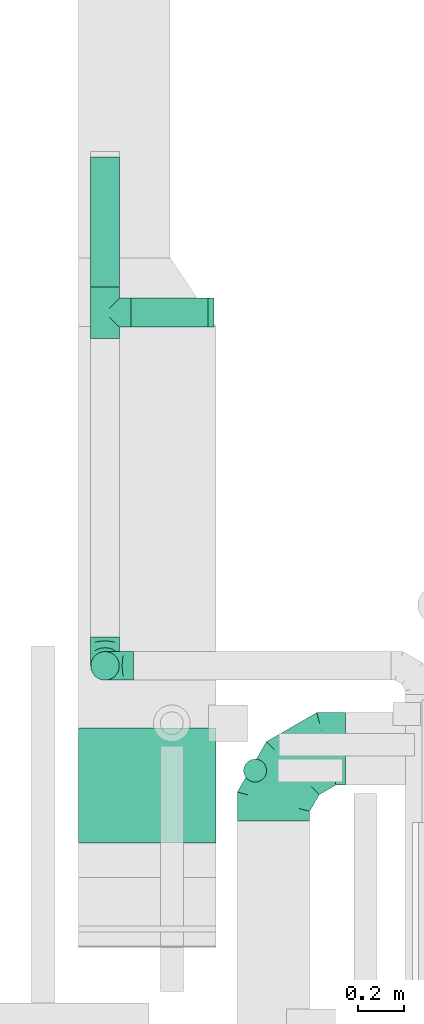
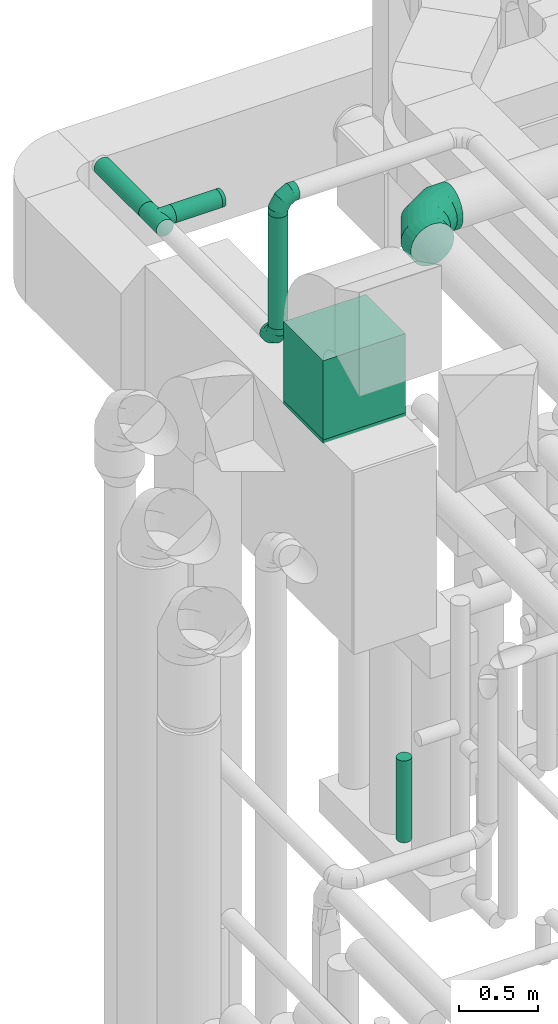
# One storey, part 273 of 337: 6 flow fittings, 5 flow segments.
"""IFC2X3 building model written with IfcOpenShell, lengths in millimetres."""

from ifc_helpers import new_model, entity, si_unit, converted_unit, derived_unit, direction, frame, origin, origin_2d_with_axis, place, context, subcontext, project, spatial, rectangle, circle, extrude, faceted_brep, source, transform, mapped, material, type_object, type_shapes, element, save


model = new_model("IFC2X3")

# Units and contexts
model_context = context("Model", 3, precision=0.01, world=origin(), true_north=direction((6.12303176911189e-17, 1.0)))
body_context = subcontext(model_context, "Body", "Model", "MODEL_VIEW")
ifc_project = project(units=[si_unit("LENGTHUNIT", "METRE", prefix="MILLI"), si_unit("AREAUNIT", "SQUARE_METRE"), si_unit("VOLUMEUNIT", "CUBIC_METRE"), converted_unit("PLANEANGLEUNIT", "DEGREE", entity("IfcRatioMeasure", 0.0174532925199433), si_unit("PLANEANGLEUNIT", "RADIAN"), dimensions=[0, 0, 0, 0, 0, 0, 0]), si_unit("MASSUNIT", "GRAM", prefix="KILO"), derived_unit("MASSDENSITYUNIT", [(si_unit("MASSUNIT", "GRAM", prefix="KILO"), 1), (si_unit("LENGTHUNIT", "METRE"), -3)]), derived_unit("MOMENTOFINERTIAUNIT", [(si_unit("LENGTHUNIT", "METRE"), 4)]), si_unit("TIMEUNIT", "SECOND"), si_unit("FREQUENCYUNIT", "HERTZ"), si_unit("THERMODYNAMICTEMPERATUREUNIT", "DEGREE_CELSIUS"), derived_unit("THERMALTRANSMITTANCEUNIT", [(si_unit("MASSUNIT", "GRAM", prefix="KILO"), 1), (si_unit("THERMODYNAMICTEMPERATUREUNIT", "KELVIN"), -1), (si_unit("TIMEUNIT", "SECOND"), -3)]), derived_unit("VOLUMETRICFLOWRATEUNIT", [(si_unit("LENGTHUNIT", "METRE"), 3), (si_unit("TIMEUNIT", "SECOND"), -1)]), derived_unit("MASSFLOWRATEUNIT", [(si_unit("MASSUNIT", "GRAM", prefix="KILO"), 1), (si_unit("TIMEUNIT", "SECOND"), -1)]), derived_unit("ROTATIONALFREQUENCYUNIT", [(si_unit("TIMEUNIT", "SECOND"), -1)]), si_unit("ELECTRICCURRENTUNIT", "AMPERE"), si_unit("ELECTRICVOLTAGEUNIT", "VOLT"), si_unit("POWERUNIT", "WATT"), si_unit("FORCEUNIT", "NEWTON", prefix="KILO"), si_unit("ILLUMINANCEUNIT", "LUX"), si_unit("LUMINOUSFLUXUNIT", "LUMEN"), si_unit("LUMINOUSINTENSITYUNIT", "CANDELA"), derived_unit("USERDEFINED", [(si_unit("MASSUNIT", "GRAM", prefix="KILO"), -1), (si_unit("LENGTHUNIT", "METRE"), -2), (si_unit("TIMEUNIT", "SECOND"), 3), (si_unit("LUMINOUSFLUXUNIT", "LUMEN"), 1)]), derived_unit("LINEARVELOCITYUNIT", [(si_unit("LENGTHUNIT", "METRE"), 1), (si_unit("TIMEUNIT", "SECOND"), -1)]), si_unit("PRESSUREUNIT", "PASCAL"), derived_unit("USERDEFINED", [(si_unit("LENGTHUNIT", "METRE"), -2), (si_unit("MASSUNIT", "GRAM", prefix="KILO"), 1), (si_unit("TIMEUNIT", "SECOND"), -2)]), derived_unit("LINEARFORCEUNIT", [(si_unit("MASSUNIT", "GRAM", prefix="KILO"), 1), (si_unit("LENGTHUNIT", "METRE"), 1), (si_unit("TIMEUNIT", "SECOND"), -2), (si_unit("LENGTHUNIT", "METRE"), -1)]), derived_unit("PLANARFORCEUNIT", [(si_unit("MASSUNIT", "GRAM", prefix="KILO"), 1), (si_unit("LENGTHUNIT", "METRE"), 1), (si_unit("TIMEUNIT", "SECOND"), -2), (si_unit("LENGTHUNIT", "METRE"), -2)])], contexts=[model_context])

# Site, building, storey
site_placement = place(None, origin())
site = spatial("IfcSite", under=ifc_project, at=site_placement, CompositionType="ELEMENT")
building_placement = place(site_placement, origin())
building = spatial("IfcBuilding", under=site, at=building_placement, CompositionType="ELEMENT")
storey_placement = place(building_placement, origin())
storey = spatial("IfcBuildingStorey", under=building, at=storey_placement, CompositionType="ELEMENT", Elevation=0.0)

# Flow segments
duct_segment_type_1 = type_object("IfcDuctSegmentType", PredefinedType="NOTDEFINED")
flow_segment_1_placement = place(storey_placement, frame((69255.37, 13033.52, 34370.0)))
element("IfcFlowSegment", 1, at=flow_segment_1_placement, inside=storey, type_object=duct_segment_type_1, context=body_context, shape_type="SweptSolid", body=[
    extrude(rectangle(XDim=600.000000000002, YDim=499.999999999999, at=origin_2d_with_axis()), frame((300.0, 250.0, 0.0)), (0.0, 0.0, 1.0), 610.000000000264),
])
duct_segment_type_2 = type_object("IfcDuctSegmentType", PredefinedType="NOTDEFINED")
flow_segment_2_placement = place(storey_placement, frame((69307.84, 13740.9, 34755.0)))
element("IfcFlowSegment", 2, at=flow_segment_2_placement, inside=storey, type_object=duct_segment_type_2, context=body_context, shape_type="SweptSolid", body=[
    extrude(circle(Radius=62.5, at=origin_2d_with_axis()), frame((64.1, 64.1, 0.0), z_axis=(0.0, 0.0, 1.0), x_axis=(0.0, -1.0, 0.0)), (0.0, 0.0, 1.0), 859.999999999995),
])
flow_segment_3_placement = place(storey_placement, frame((69974.7, 13296.82, 30840.0)))
element("IfcFlowSegment", 3, at=flow_segment_3_placement, inside=storey, type_object=duct_segment_type_2, context=body_context, shape_type="SweptSolid", body=[
    extrude(circle(Radius=50.0, at=origin_2d_with_axis()), frame((51.6, 51.6, 0.0), z_axis=(0.0, 0.0, 1.0), x_axis=(0.0, 1.0, 0.0)), (0.0, 0.0, 1.0), 630.000000000017),
])
flow_segment_4_placement = place(storey_placement, frame((69484.44, 15280.9, 34565.9)))
element("IfcFlowSegment", 4, at=flow_segment_4_placement, inside=storey, type_object=duct_segment_type_2, context=body_context, shape_type="SweptSolid", body=[
    extrude(circle(Radius=62.5, at=origin_2d_with_axis()), frame((0.0, 64.1, 64.1), z_axis=(1.0, 0.0, 0.0), x_axis=(0.0, -1.0, 0.0)), (0.0, 0.0, 1.0), 337.500000000001),
])
flow_segment_5_placement = place(storey_placement, frame((69307.84, 15457.5, 34565.9)))
element("IfcFlowSegment", 5, at=flow_segment_5_placement, inside=storey, type_object=duct_segment_type_2, context=body_context, shape_type="SweptSolid", body=[
    extrude(circle(Radius=62.5, at=origin_2d_with_axis()), frame((64.1, 0.0, 64.1), z_axis=(0.0, 1.0, 0.0), x_axis=(1.0, 0.0, 0.0)), (0.0, 0.0, 1.0), 564.999999999999),
])

# Flow fittings
ifc_material = material()
duct_fitting_type_1 = type_object("IfcDuctFittingType", PredefinedType="NOTDEFINED", material=ifc_material)
shared_shape_1 = source(origin(), body_context, "Body", "SweptSolid", [
    extrude(circle(Radius=62.4999999999996, at=origin_2d_with_axis()), frame((0.0, 0.0, 0.0), z_axis=(1.0, 0.0, 0.0), x_axis=(0.0, 1.0, 0.0)), (0.0, 0.0, 1.0), 25.0000000000018),
])
type_shapes(duct_fitting_type_1, [shared_shape_1])
flow_fitting_1_placement = place(storey_placement, frame((69821.94, 15345.0, 34630.0)))
element("IfcFlowFitting", 6, at=flow_fitting_1_placement, inside=storey, type_object=duct_fitting_type_1, material=ifc_material, context=body_context, shape_type="MappedRepresentation", body=[
    mapped(shared_shape_1, transform((0.0, 0.0, 0.0), scale=1.0)),
])
duct_fitting_type_2 = type_object("IfcDuctFittingType", PredefinedType="NOTDEFINED", material=ifc_material)
shared_shape_2 = source(origin(), body_context, "Body", "SweptSolid", [
    extrude(rectangle(XDim=600.0, YDim=26.096, at=origin_2d_with_axis()), frame((6.95, 0.0, -250.0), z_axis=(0.0, 0.0, 1.0), x_axis=(0.0, -1.0, 0.0)), (0.0, 0.0, 1.0), 500.0),
])
type_shapes(duct_fitting_type_2, [shared_shape_2])
flow_fitting_2_placement = place(storey_placement, frame((69555.37, 13283.52, 34350.0), z_axis=(0.0, 1.0, 0.0), x_axis=(0.0, 0.0, 1.0)))
element("IfcFlowFitting", 7, at=flow_fitting_2_placement, inside=storey, type_object=duct_fitting_type_2, material=ifc_material, context=body_context, shape_type="MappedRepresentation", body=[
    mapped(shared_shape_2, transform((0.0, 0.0, 0.0), scale=1.0)),
])
duct_fitting_type_3 = type_object("IfcDuctFittingType", PredefinedType="NOTDEFINED", material=ifc_material)
shared_shape_3 = source(origin(), body_context, "Body", "Brep", [
    faceted_brep([(-125.0, 0.0, -62.5), (-125.0, -16.18, -60.37), (-125.0, -31.25, -54.13), (-125.0, -44.19, -44.19), (-125.0, -54.13, -31.25), (-125.0, -60.37, -16.18), (-125.0, -62.5, 0.0), (-125.0, -60.37, 16.18), (-125.0, -54.13, 31.25), (-125.0, -44.19, 44.19), (-125.0, -31.25, 54.13), (-125.0, -16.18, 60.37), (-125.0, 0.0, 62.5), (-125.0, 16.18, 60.37), (-125.0, 31.25, 54.13), (-125.0, 44.19, 44.19), (-125.0, 54.13, 31.25), (-125.0, 60.37, 16.18), (-125.0, 62.5, 0.0), (-125.0, 60.37, -16.18), (-125.0, 54.13, -31.25), (-125.0, 44.19, -44.19), (-125.0, 31.25, -54.13), (-125.0, 16.18, -60.37), (-95.84, 16.18, 60.37), (-99.88, 31.25, 54.13), (-91.51, 0.0, 62.5), (-103.35, 44.19, 44.19), (-107.68, 60.37, 16.18), (-108.25, 62.5, 0.0), (-106.01, 54.13, 31.25), (-106.01, 54.13, -31.25), (-103.35, 44.19, -44.19), (-107.68, 60.37, -16.18), (-95.84, 16.18, -60.37), (-91.51, 0.0, -62.5), (-99.88, 31.25, -54.13), (-87.17, -16.18, -60.37), (-83.13, -31.25, -54.13), (-79.66, -44.19, -44.19), (-77.0, -54.13, -31.25), (-75.33, -60.37, -16.18), (-74.76, -62.5, 0.0), (-75.33, -60.37, 16.18), (-77.0, -54.13, 31.25), (-79.66, -44.19, 44.19), (-83.13, -31.25, 54.13), (-87.17, -16.18, 60.37), (-45.34, 45.34, 60.37), (-56.37, 56.37, 54.13), (-33.49, 33.49, 62.5), (-65.85, 65.85, 44.19), (-73.12, 73.12, 31.25), (-77.69, 77.69, 16.18), (-79.25, 79.25, 0.0), (-77.69, 77.69, -16.18), (-73.12, 73.12, -31.25), (-65.85, 65.85, -44.19), (-45.34, 45.34, -60.37), (-33.49, 33.49, -62.5), (-56.37, 56.37, -54.13), (-21.65, 21.65, -60.37), (-10.62, 10.62, -54.13), (-1.14, 1.14, -44.19), (6.13, -6.13, -31.25), (10.7, -10.7, -16.18), (12.26, -12.26, 0.0), (10.7, -10.7, 16.18), (6.13, -6.13, 31.25), (-1.14, 1.14, 44.19), (-10.62, 10.62, 54.13), (-21.65, 21.65, 60.37), (-16.18, 95.84, 60.37), (-31.25, 99.88, 54.13), (0.0, 91.51, 62.5), (-44.19, 103.35, 44.19), (-54.13, 106.01, 31.25), (-60.37, 107.68, 16.18), (-62.5, 108.25, 0.0), (-60.37, 107.68, -16.18), (-54.13, 106.01, -31.25), (-44.19, 103.35, -44.19), (-16.18, 95.84, -60.37), (0.0, 91.51, -62.5), (-31.25, 99.88, -54.13), (16.18, 87.17, -60.37), (31.25, 83.13, -54.13), (44.19, 79.66, -44.19), (54.13, 77.0, -31.25), (60.37, 75.33, -16.18), (62.5, 74.76, 0.0), (60.37, 75.33, 16.18), (54.13, 77.0, 31.25), (44.19, 79.66, 44.19), (31.25, 83.13, 54.13), (16.18, 87.17, 60.37), (-16.18, 125.0, -60.37), (-31.25, 125.0, -54.13), (-44.19, 125.0, -44.19), (-54.13, 125.0, -31.25), (-60.37, 125.0, -16.18), (-62.5, 125.0, 0.0), (-60.37, 125.0, 16.18), (-54.13, 125.0, 31.25), (-44.19, 125.0, 44.19), (-31.25, 125.0, 54.13), (-16.18, 125.0, 60.37), (0.0, 125.0, 62.5), (16.18, 125.0, 60.37), (31.25, 125.0, 54.13), (44.19, 125.0, 44.19), (54.13, 125.0, 31.25), (60.37, 125.0, 16.18), (62.5, 125.0, 0.0), (60.37, 125.0, -16.18), (54.13, 125.0, -31.25), (44.19, 125.0, -44.19), (31.25, 125.0, -54.13), (16.18, 125.0, -60.37), (0.0, 125.0, -62.5)], [[[0, 1, 2, 3, 4, 5, 6, 7, 8, 9, 10, 11, 12, 13, 14, 15, 16, 17, 18, 19, 20, 21, 22, 23]], [[24, 25, 14, 13]], [[26, 24, 13, 12]], [[14, 25, 27, 15]], [[28, 29, 18, 17]], [[30, 28, 17, 16]], [[15, 27, 30, 16]], [[20, 31, 32, 21]], [[33, 31, 20, 19]], [[18, 29, 33, 19]], [[34, 35, 0, 23]], [[36, 34, 23, 22]], [[21, 32, 36, 22]], [[1, 0, 35, 37]], [[2, 1, 37, 38]], [[38, 39, 3, 2]], [[5, 4, 40, 41]], [[6, 5, 41, 42]], [[39, 40, 4, 3]], [[6, 42, 43, 7]], [[7, 43, 44, 8]], [[45, 9, 8, 44]], [[9, 45, 46, 10]], [[10, 46, 47, 11]], [[26, 12, 11, 47]], [[48, 49, 25, 24]], [[50, 48, 24, 26]], [[27, 25, 49, 51]], [[52, 53, 28, 30]], [[51, 52, 30, 27]], [[29, 28, 53, 54]], [[55, 56, 31, 33]], [[54, 55, 33, 29]], [[57, 32, 31, 56]], [[58, 59, 35, 34]], [[60, 58, 34, 36]], [[57, 60, 36, 32]], [[37, 35, 59, 61]], [[38, 37, 61, 62]], [[39, 38, 62, 63]], [[41, 40, 64, 65]], [[42, 41, 65, 66]], [[63, 64, 40, 39]], [[43, 42, 66, 67]], [[44, 43, 67, 68]], [[68, 69, 45, 44]], [[46, 45, 69, 70]], [[47, 46, 70, 71]], [[26, 47, 71, 50]], [[72, 73, 49, 48]], [[74, 72, 48, 50]], [[51, 49, 73, 75]], [[76, 77, 53, 52]], [[75, 76, 52, 51]], [[54, 53, 77, 78]], [[79, 80, 56, 55]], [[78, 79, 55, 54]], [[81, 57, 56, 80]], [[82, 83, 59, 58]], [[84, 82, 58, 60]], [[81, 84, 60, 57]], [[61, 59, 83, 85]], [[62, 61, 85, 86]], [[63, 62, 86, 87]], [[65, 64, 88, 89]], [[66, 65, 89, 90]], [[87, 88, 64, 63]], [[67, 66, 90, 91]], [[68, 67, 91, 92]], [[92, 93, 69, 68]], [[70, 69, 93, 94]], [[71, 70, 94, 95]], [[50, 71, 95, 74]], [[96, 97, 98, 99, 100, 101, 102, 103, 104, 105, 106, 107, 108, 109, 110, 111, 112, 113, 114, 115, 116, 117, 118, 119]], [[72, 74, 107, 106]], [[73, 72, 106, 105]], [[75, 73, 105, 104]], [[77, 76, 103, 102]], [[78, 77, 102, 101]], [[75, 104, 103, 76]], [[78, 101, 100, 79]], [[79, 100, 99, 80]], [[80, 99, 98, 81]], [[96, 119, 83, 82]], [[97, 96, 82, 84]], [[84, 81, 98, 97]], [[83, 119, 118, 85]], [[85, 118, 117, 86]], [[116, 87, 86, 117]], [[88, 115, 114, 89]], [[89, 114, 113, 90]], [[115, 88, 87, 116]], [[91, 90, 113, 112]], [[92, 91, 112, 111]], [[111, 110, 93, 92]], [[95, 94, 109, 108]], [[74, 95, 108, 107]], [[110, 109, 94, 93]]]),
])
type_shapes(duct_fitting_type_3, [shared_shape_3])
for number, where, z_axis, x_axis in (
    (8, (69371.94, 13805.0, 34630.0), (-1.0, 0.0, 0.0), (0.0, -1.0, 0.0)),
    (9, (69371.94, 13805.0, 35740.0), (0.0, 1.0, 0.0), (0.0, 0.0, 1.0)),
):
    element("IfcFlowFitting", number, at=place(storey_placement, frame(where, z_axis=z_axis, x_axis=x_axis)), inside=storey, type_object=duct_fitting_type_3, material=ifc_material, context=body_context, shape_type="MappedRepresentation", body=[
        mapped(shared_shape_3, transform((0.0, 0.0, 0.0), scale=1.0)),
    ])
duct_fitting_type_4 = type_object("IfcDuctFittingType", PredefinedType="NOTDEFINED", material=ifc_material)
shared_shape_4 = source(origin(), body_context, "Body", "Brep", [
    faceted_brep([(-315.0, 0.0, -157.5), (-315.0, -40.76, -152.13), (-315.0, -78.75, -136.4), (-315.0, -111.37, -111.37), (-315.0, -136.4, -78.75), (-315.0, -152.13, -40.76), (-315.0, -157.5, 0.0), (-315.0, -152.13, 40.76), (-315.0, -136.4, 78.75), (-315.0, -111.37, 111.37), (-315.0, -78.75, 136.4), (-315.0, -40.76, 152.13), (-315.0, 0.0, 157.5), (-315.0, 40.76, 152.13), (-315.0, 78.75, 136.4), (-315.0, 111.37, 111.37), (-315.0, 136.4, 78.75), (-315.0, 152.13, 40.76), (-315.0, 157.5, 0.0), (-315.0, 152.13, -40.76), (-315.0, 136.4, -78.75), (-315.0, 111.37, -111.37), (-315.0, 78.75, -136.4), (-315.0, 40.76, -152.13), (-241.52, 40.76, 152.13), (-251.7, 78.75, 136.4), (-230.6, 0.0, 157.5), (-260.44, 111.37, 111.37), (-271.36, 152.13, 40.76), (-272.8, 157.5, 0.0), (-267.14, 136.4, 78.75), (-267.14, 136.4, -78.75), (-260.44, 111.37, -111.37), (-271.36, 152.13, -40.76), (-241.52, 40.76, -152.13), (-230.6, 0.0, -157.5), (-251.7, 78.75, -136.4), (-219.67, -40.76, -152.13), (-209.5, -78.75, -136.4), (-200.75, -111.37, -111.37), (-194.05, -136.4, -78.75), (-189.83, -152.13, -40.76), (-188.39, -157.5, 0.0), (-189.83, -152.13, 40.76), (-194.05, -136.4, 78.75), (-200.75, -111.37, 111.37), (-209.5, -78.75, 136.4), (-219.67, -40.76, 152.13), (-114.25, 114.25, 152.13), (-142.05, 142.05, 136.4), (-84.4, 84.4, 157.5), (-165.93, 165.93, 111.37), (-184.25, 184.25, 78.75), (-195.77, 195.77, 40.76), (-199.7, 199.7, 0.0), (-195.77, 195.77, -40.76), (-184.25, 184.25, -78.75), (-165.93, 165.93, -111.37), (-114.25, 114.25, -152.13), (-84.4, 84.4, -157.5), (-142.05, 142.05, -136.4), (-54.56, 54.56, -152.13), (-26.75, 26.75, -136.4), (-2.88, 2.88, -111.37), (15.45, -15.45, -78.75), (26.97, -26.97, -40.76), (30.89, -30.89, 0.0), (26.97, -26.97, 40.76), (15.45, -15.45, 78.75), (-2.88, 2.88, 111.37), (-26.75, 26.75, 136.4), (-54.56, 54.56, 152.13), (-40.76, 241.52, 152.13), (-78.75, 251.7, 136.4), (0.0, 230.6, 157.5), (-111.37, 260.44, 111.37), (-136.4, 267.14, 78.75), (-152.13, 271.36, 40.76), (-157.5, 272.8, 0.0), (-152.13, 271.36, -40.76), (-136.4, 267.14, -78.75), (-111.37, 260.44, -111.37), (-40.76, 241.52, -152.13), (0.0, 230.6, -157.5), (-78.75, 251.7, -136.4), (40.76, 219.67, -152.13), (78.75, 209.5, -136.4), (111.37, 200.75, -111.37), (136.4, 194.05, -78.75), (152.13, 189.83, -40.76), (157.5, 188.39, 0.0), (152.13, 189.83, 40.76), (136.4, 194.05, 78.75), (111.37, 200.75, 111.37), (78.75, 209.5, 136.4), (40.76, 219.67, 152.13), (-40.76, 315.0, -152.13), (-78.75, 315.0, -136.4), (-111.37, 315.0, -111.37), (-136.4, 315.0, -78.75), (-152.13, 315.0, -40.76), (-157.5, 315.0, 0.0), (-152.13, 315.0, 40.76), (-136.4, 315.0, 78.75), (-111.37, 315.0, 111.37), (-78.75, 315.0, 136.4), (-40.76, 315.0, 152.13), (0.0, 315.0, 157.5), (40.76, 315.0, 152.13), (78.75, 315.0, 136.4), (111.37, 315.0, 111.37), (136.4, 315.0, 78.75), (152.13, 315.0, 40.76), (157.5, 315.0, 0.0), (152.13, 315.0, -40.76), (136.4, 315.0, -78.75), (111.37, 315.0, -111.37), (78.75, 315.0, -136.4), (40.76, 315.0, -152.13), (0.0, 315.0, -157.5)], [[[0, 1, 2, 3, 4, 5, 6, 7, 8, 9, 10, 11, 12, 13, 14, 15, 16, 17, 18, 19, 20, 21, 22, 23]], [[24, 25, 14, 13]], [[26, 24, 13, 12]], [[14, 25, 27, 15]], [[28, 29, 18, 17]], [[30, 28, 17, 16]], [[15, 27, 30, 16]], [[20, 31, 32, 21]], [[33, 31, 20, 19]], [[18, 29, 33, 19]], [[34, 35, 0, 23]], [[36, 34, 23, 22]], [[32, 36, 22, 21]], [[1, 0, 35, 37]], [[2, 1, 37, 38]], [[38, 39, 3, 2]], [[5, 4, 40, 41]], [[6, 5, 41, 42]], [[39, 40, 4, 3]], [[6, 42, 43, 7]], [[7, 43, 44, 8]], [[8, 44, 45, 9]], [[9, 45, 46, 10]], [[10, 46, 47, 11]], [[26, 12, 11, 47]], [[48, 49, 25, 24]], [[50, 48, 24, 26]], [[27, 25, 49, 51]], [[52, 53, 28, 30]], [[51, 52, 30, 27]], [[29, 28, 53, 54]], [[55, 56, 31, 33]], [[54, 55, 33, 29]], [[32, 31, 56, 57]], [[58, 59, 35, 34]], [[60, 58, 34, 36]], [[57, 60, 36, 32]], [[37, 35, 59, 61]], [[38, 37, 61, 62]], [[39, 38, 62, 63]], [[41, 40, 64, 65]], [[42, 41, 65, 66]], [[63, 64, 40, 39]], [[43, 42, 66, 67]], [[44, 43, 67, 68]], [[68, 69, 45, 44]], [[46, 45, 69, 70]], [[47, 46, 70, 71]], [[26, 47, 71, 50]], [[72, 73, 49, 48]], [[74, 72, 48, 50]], [[51, 49, 73, 75]], [[76, 77, 53, 52]], [[75, 76, 52, 51]], [[54, 53, 77, 78]], [[79, 80, 56, 55]], [[78, 79, 55, 54]], [[57, 56, 80, 81]], [[82, 83, 59, 58]], [[84, 82, 58, 60]], [[81, 84, 60, 57]], [[61, 59, 83, 85]], [[62, 61, 85, 86]], [[63, 62, 86, 87]], [[65, 64, 88, 89]], [[66, 65, 89, 90]], [[87, 88, 64, 63]], [[67, 66, 90, 91]], [[68, 67, 91, 92]], [[92, 93, 69, 68]], [[70, 69, 93, 94]], [[71, 70, 94, 95]], [[50, 71, 95, 74]], [[96, 97, 98, 99, 100, 101, 102, 103, 104, 105, 106, 107, 108, 109, 110, 111, 112, 113, 114, 115, 116, 117, 118, 119]], [[106, 105, 73, 72]], [[107, 106, 72, 74]], [[75, 73, 105, 104]], [[77, 76, 103, 102]], [[78, 77, 102, 101]], [[104, 103, 76, 75]], [[78, 101, 100, 79]], [[79, 100, 99, 80]], [[98, 81, 80, 99]], [[84, 97, 96, 82]], [[82, 96, 119, 83]], [[97, 84, 81, 98]], [[83, 119, 118, 85]], [[85, 118, 117, 86]], [[116, 87, 86, 117]], [[88, 115, 114, 89]], [[89, 114, 113, 90]], [[115, 88, 87, 116]], [[91, 90, 113, 112]], [[92, 91, 112, 111]], [[111, 110, 93, 92]], [[95, 94, 109, 108]], [[74, 95, 108, 107]], [[110, 109, 94, 93]]]),
])
type_shapes(duct_fitting_type_4, [shared_shape_4])
flow_fitting_3_placement = place(storey_placement, frame((70106.26, 13443.57, 35520.0), z_axis=(0.0, 0.0, 1.0), x_axis=(-1.0, 0.0, 0.0)))
element("IfcFlowFitting", 10, at=flow_fitting_3_placement, inside=storey, type_object=duct_fitting_type_4, material=ifc_material, context=body_context, shape_type="MappedRepresentation", body=[
    mapped(shared_shape_4, transform((0.0, 0.0, 0.0), scale=1.0)),
])
duct_fitting_type_5 = type_object("IfcDuctFittingType", PredefinedType="NOTDEFINED", material=ifc_material)
shared_shape_5 = source(origin(), body_context, "Body", "Brep", [
    faceted_brep([(9.35, -9.35, -61.8), (112.5, 0.0, -62.5), (112.5, -16.18, -60.37), (112.5, -31.25, -54.13), (27.61, -27.61, -56.07), (36.24, -36.24, -50.92), (112.5, -44.19, -44.19), (0.0, 0.0, -62.5), (-9.35, -9.35, -61.8), (-112.5, 0.0, -62.5), (18.59, -18.59, -59.67), (51.42, -51.42, -35.53), (112.5, -54.13, -31.25), (57.22, -57.22, -25.14), (112.5, -60.37, -16.18), (61.11, -61.11, -13.09), (112.5, -62.5, 0.0), (44.28, -44.28, -44.11), (62.5, -62.5, 0.0), (-112.5, -62.5, 0.0), (-61.11, -61.11, -13.09), (-62.5, -62.5, 0.0), (61.11, -61.11, 13.09), (-61.11, -61.11, 13.09), (112.5, -60.37, 16.18), (57.22, -57.22, 25.14), (112.5, -54.13, 31.25), (112.5, -44.19, 44.19), (44.28, -44.28, 44.11), (51.42, -51.42, 35.53), (36.24, -36.24, 50.92), (112.5, -31.25, 54.13), (27.61, -27.61, 56.07), (112.5, -16.18, 60.37), (9.35, -9.35, 61.8), (112.5, 0.0, 62.5), (18.59, -18.59, 59.67), (0.0, 0.0, 62.5), (-9.35, -9.35, 61.8), (-112.5, 0.0, 62.5), (16.18, -112.5, -60.37), (31.25, -112.5, -54.13), (44.19, -112.5, -44.19), (54.13, -112.5, -31.25), (60.37, -112.5, -16.18), (62.5, -112.5, 0.0), (60.37, -112.5, 16.18), (54.13, -112.5, 31.25), (44.19, -112.5, 44.19), (31.25, -112.5, 54.13), (16.18, -112.5, 60.37), (0.0, -112.5, 62.5), (-16.18, -112.5, 60.37), (-31.25, -112.5, 54.13), (-44.19, -112.5, 44.19), (-54.13, -112.5, 31.25), (-60.37, -112.5, 16.18), (-62.5, -112.5, 0.0), (-60.37, -112.5, -16.18), (-54.13, -112.5, -31.25), (-44.19, -112.5, -44.19), (-31.25, -112.5, -54.13), (-16.18, -112.5, -60.37), (0.0, -112.5, -62.5), (-27.61, -27.61, -56.07), (-36.24, -36.24, -50.92), (-18.59, -18.59, -59.67), (-51.42, -51.42, -35.53), (-57.22, -57.22, -25.14), (-44.28, -44.28, -44.11), (-57.22, -57.22, 25.14), (-44.28, -44.28, 44.11), (-51.42, -51.42, 35.53), (-36.24, -36.24, 50.92), (-27.61, -27.61, 56.07), (-18.59, -18.59, 59.67), (-112.5, -16.18, -60.37), (-112.5, -31.25, -54.13), (-112.5, -44.19, -44.19), (-112.5, -54.13, -31.25), (-112.5, -60.37, -16.18), (-112.5, -60.37, 16.18), (-112.5, -54.13, 31.25), (-112.5, -44.19, 44.19), (-112.5, -31.25, 54.13), (-112.5, -16.18, 60.37), (-112.5, 16.18, 60.37), (-112.5, 31.25, 54.13), (-112.5, 44.19, 44.19), (-112.5, 54.13, 31.25), (-112.5, 60.37, 16.18), (-112.5, 62.5, 0.0), (-112.5, 60.37, -16.18), (-112.5, 54.13, -31.25), (-112.5, 44.19, -44.19), (-112.5, 31.25, -54.13), (-112.5, 16.18, -60.37), (112.5, 16.18, -60.37), (112.5, 31.25, -54.13), (112.5, 44.19, -44.19), (112.5, 54.13, -31.25), (112.5, 60.37, -16.18), (112.5, 62.5, 0.0), (112.5, 60.37, 16.18), (112.5, 54.13, 31.25), (112.5, 44.19, 44.19), (112.5, 31.25, 54.13), (112.5, 16.18, 60.37)], [[[0, 1, 2]], [[2, 3, 4]], [[5, 3, 6]], [[5, 4, 3]], [[0, 7, 1]], [[7, 8, 9]], [[4, 10, 2]], [[0, 2, 10]], [[11, 6, 12]], [[13, 12, 14]], [[15, 14, 16]], [[11, 17, 6]], [[15, 13, 14]], [[18, 15, 16]], [[19, 20, 21]], [[11, 12, 13]], [[6, 17, 5]], [[22, 18, 16]], [[21, 23, 19]], [[22, 16, 24]], [[25, 24, 26]], [[25, 22, 24]], [[27, 28, 29]], [[25, 26, 29]], [[29, 26, 27]], [[30, 27, 31]], [[32, 31, 33]], [[34, 33, 35]], [[32, 30, 31]], [[34, 36, 33]], [[37, 34, 35]], [[38, 37, 39]], [[32, 33, 36]], [[27, 30, 28]], [[40, 41, 42, 43, 44, 45, 46, 47, 48, 49, 50, 51, 52, 53, 54, 55, 56, 57, 58, 59, 60, 61, 62, 63]], [[34, 51, 50]], [[50, 49, 32]], [[30, 49, 48]], [[30, 32, 49]], [[34, 37, 51]], [[32, 36, 50]], [[34, 50, 36]], [[29, 48, 47]], [[25, 47, 46]], [[22, 46, 45]], [[29, 28, 48]], [[22, 25, 46]], [[18, 22, 45]], [[29, 47, 25]], [[48, 28, 30]], [[15, 18, 45]], [[15, 45, 44]], [[13, 44, 43]], [[13, 15, 44]], [[42, 17, 11]], [[13, 43, 11]], [[11, 43, 42]], [[5, 42, 41]], [[4, 41, 40]], [[0, 40, 63]], [[4, 5, 41]], [[0, 10, 40]], [[7, 0, 63]], [[4, 40, 10]], [[42, 5, 17]], [[8, 63, 62]], [[62, 61, 64]], [[65, 61, 60]], [[65, 64, 61]], [[8, 7, 63]], [[64, 66, 62]], [[8, 62, 66]], [[67, 60, 59]], [[68, 59, 58]], [[20, 58, 57]], [[67, 69, 60]], [[20, 68, 58]], [[21, 20, 57]], [[67, 59, 68]], [[60, 69, 65]], [[23, 21, 57]], [[23, 57, 56]], [[70, 56, 55]], [[70, 23, 56]], [[54, 71, 72]], [[70, 55, 72]], [[72, 55, 54]], [[73, 54, 53]], [[74, 53, 52]], [[38, 52, 51]], [[74, 73, 53]], [[38, 75, 52]], [[37, 38, 51]], [[74, 52, 75]], [[54, 73, 71]], [[9, 76, 77, 78, 79, 80, 19, 81, 82, 83, 84, 85, 39, 86, 87, 88, 89, 90, 91, 92, 93, 94, 95, 96]], [[97, 98, 99, 100, 101, 102, 103, 104, 105, 106, 107, 35, 33, 31, 27, 26, 24, 16, 14, 12, 6, 3, 2, 1]], [[37, 35, 107, 86, 39]], [[87, 86, 107, 106]], [[106, 105, 88, 87]], [[89, 88, 105, 104]], [[90, 89, 104, 103]], [[91, 90, 103, 102]], [[101, 100, 93, 92]], [[102, 101, 92, 91]], [[100, 99, 94, 93]], [[95, 94, 99, 98]], [[96, 95, 98, 97]], [[7, 9, 96, 97, 1]], [[66, 64, 76]], [[8, 66, 76]], [[9, 8, 76]], [[77, 65, 78]], [[77, 76, 64]], [[65, 77, 64]], [[69, 67, 78]], [[68, 20, 80]], [[67, 68, 79]], [[78, 67, 79]], [[20, 19, 80]], [[80, 79, 68]], [[69, 78, 65]], [[23, 70, 81]], [[82, 72, 83]], [[70, 72, 82]], [[19, 23, 81]], [[70, 82, 81]], [[72, 71, 83]], [[74, 75, 85]], [[75, 38, 85]], [[83, 73, 84]], [[73, 83, 71]], [[74, 84, 73]], [[74, 85, 84]], [[38, 39, 85]]]),
])
type_shapes(duct_fitting_type_5, [shared_shape_5])
flow_fitting_4_placement = place(storey_placement, frame((69371.94, 15345.0, 34630.0), z_axis=(0.0, 0.0, 1.0), x_axis=(0.0, 1.0, 0.0)))
element("IfcFlowFitting", 11, at=flow_fitting_4_placement, inside=storey, type_object=duct_fitting_type_5, material=ifc_material, context=body_context, shape_type="MappedRepresentation", body=[
    mapped(shared_shape_5, transform((0.0, 0.0, 0.0), scale=1.0)),
])

save(model, "model.ifc")
